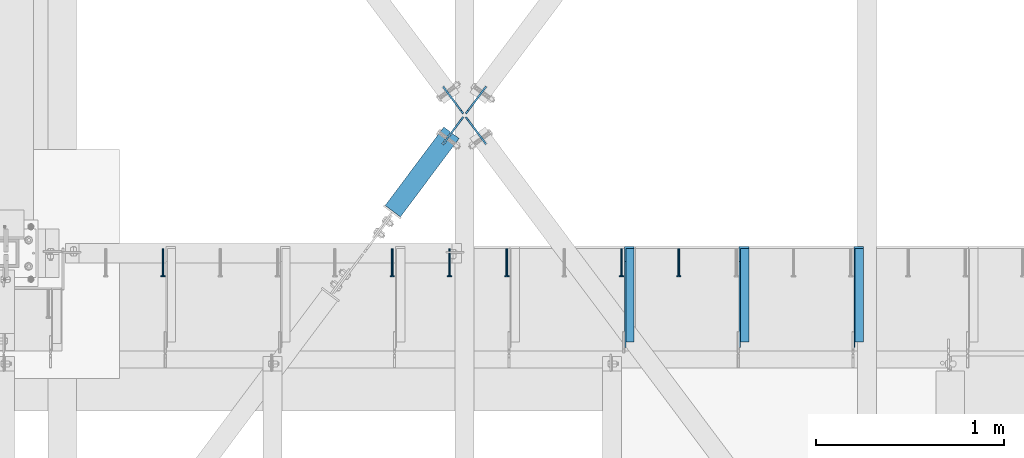
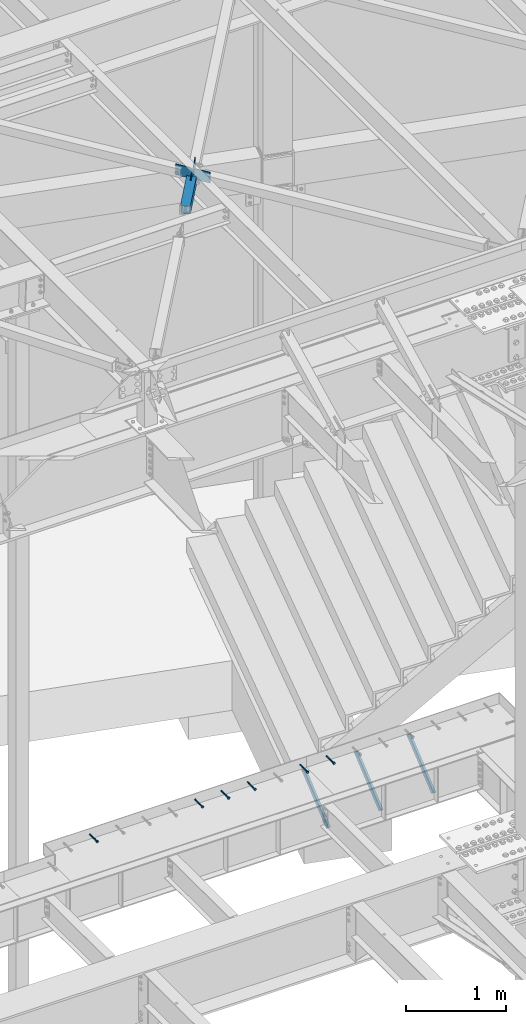
# One storey, part 1362 of 1763: 11 beams, 3 members, 9 elements without a shape of their own.
"""IFC2X3 building model written with IfcOpenShell, lengths in millimetres."""

from ifc_helpers import new_model, si_unit, frame, origin_with_axes, place, context, subcontext, project, spatial, faceted_brep, material, type_object, element, aggregate, save


model = new_model("IFC2X3")

# Units and contexts
model_context = context("Model", 3, precision=1e-05, world=origin_with_axes())
body_context = subcontext(model_context, "Body", "Model", "MODEL_VIEW")
ifc_project = project(units=[si_unit("LENGTHUNIT", "METRE", prefix="MILLI"), si_unit("AREAUNIT", "SQUARE_METRE"), si_unit("VOLUMEUNIT", "CUBIC_METRE"), si_unit("MASSUNIT", "GRAM", prefix="KILO"), si_unit("TIMEUNIT", "SECOND"), si_unit("PLANEANGLEUNIT", "RADIAN"), si_unit("SOLIDANGLEUNIT", "STERADIAN"), si_unit("THERMODYNAMICTEMPERATUREUNIT", "DEGREE_CELSIUS"), si_unit("LUMINOUSINTENSITYUNIT", "LUMEN")], contexts=[model_context])

# Site, building, storey
site_placement = place(None, origin_with_axes())
site = spatial("IfcSite", under=ifc_project, at=site_placement, CompositionType="ELEMENT")
building_placement = place(site_placement, origin_with_axes())
building = spatial("IfcBuilding", under=site, at=building_placement, Name="Undefined", CompositionType="ELEMENT")
storey_placement = place(building_placement, origin_with_axes())
storey = spatial("IfcBuildingStorey", under=building, at=storey_placement, Name="Undefined", CompositionType="ELEMENT", Elevation=0.0)

# Assembly, beam
assembly_1_placement = place(storey_placement, origin_with_axes())
assembly_1 = element("IfcElementAssembly", 1, at=assembly_1_placement, inside=storey, Name="HEADED STUD ANCHOR", AssemblyPlace="NOTDEFINED", PredefinedType="RIGID_FRAME")
ifc_material_1 = material(Name="STEEL/A108")
beam_type_1 = type_object("IfcBeamType", PredefinedType="NOTDEFINED")
beam_1_placement = place(assembly_1_placement, frame((-36392.8747736983, 54203.6, 5264.23140606069), z_axis=(0.0, 0.0, 1.0), x_axis=(0.0, -1.0, 0.0)))
beam_1 = element("IfcBeam", 2, at=beam_1_placement, type_object=beam_type_1, material=ifc_material_1, Name="HEADED STUD ANCHOR", context=body_context, shape_type="Brep", body=[
    faceted_brep([(0.0, -3.1800000667572, 5.5), (0.0, -5.5, 3.1800000667572), (141.732000000002, -5.5, 3.1800000667572), (141.732000000002, -3.1800000667572, 5.5), (0.0, -6.34999999999491, 1.45519152283669e-11), (141.732000000002, -6.34999990463257, 0.0), (0.0, -5.5, -3.1800000667572), (141.732000000002, -5.5, -3.1800000667572), (0.0, -3.1800000667572, -5.5), (141.732000000002, -3.1800000667572, -5.5), (0.0, 0.0, -6.34999990463257), (141.732000000002, 0.0, -6.34999990463257), (0.0, 3.1800000667572, -5.5), (141.732000000002, 3.1800000667572, -5.5), (0.0, 5.5, -3.1800000667572), (141.732000000002, 5.5, -3.1800000667572), (0.0, 6.34999999999491, -2.91038304567337e-11), (141.732000000002, 6.34999990463257, 0.0), (0.0, 5.5, 3.1800000667572), (141.732000000002, 5.5, 3.1800000667572), (0.0, 3.1800000667572, 5.5), (141.732000000002, 3.1800000667572, 5.5), (0.0, 0.0, 6.34999990463257), (141.732000000002, 0.0, 6.34999990463257), (144.780000000001, -10.9899997711182, 6.34999990463257), (144.780000000001, -6.34000015258789, 10.9899997711182), (144.780000000001, -12.6999998092651, 0.0), (144.780000000001, -10.9899997711182, -6.34999990463257), (144.780000000001, -6.34000015258789, -10.9899997711182), (144.780000000001, 0.0, -12.6899995803833), (144.780000000001, 6.34000015258789, -10.9899997711182), (144.780000000001, 10.9899997711182, -6.34999990463257), (144.780000000001, 12.6999998092651, 0.0), (144.780000000001, 10.9899997711182, 6.34999990463257), (144.780000000001, 6.34000015258789, 10.9899997711182), (144.780000000001, 0.0, 12.6899995803833), (152.400000000001, -10.9899997711182, 6.34999990463257), (152.400000000001, -6.34000015258789, 10.9899997711182), (152.400000000001, -12.6999998092651, 0.0), (152.400000000001, -10.9899997711182, -6.34999990463257), (152.400000000001, -6.34000015258789, -10.9899997711182), (152.400000000001, 0.0, -12.6899995803833), (152.400000000001, 6.34000015258789, -10.9899997711182), (152.400000000001, 10.9899997711182, -6.34999990463257), (152.400000000001, 12.6999998092651, 0.0), (152.400000000001, 10.9899997711182, 6.34999990463257), (152.400000000001, 6.34000015258789, 10.9899997711182), (152.400000000001, 0.0, 12.6899995803833)], [[[0, 1, 2, 3]], [[1, 4, 5, 2]], [[4, 6, 7, 5]], [[6, 8, 9, 7]], [[8, 10, 11, 9]], [[10, 12, 13, 11]], [[12, 14, 15, 13]], [[14, 16, 17, 15]], [[16, 18, 19, 17]], [[18, 20, 21, 19]], [[20, 22, 23, 21]], [[22, 0, 3, 23]], [[22, 20, 18, 16, 14, 12, 10, 8, 6, 4, 1, 0]], [[3, 2, 24, 25]], [[2, 5, 26, 24]], [[5, 7, 27, 26]], [[7, 9, 28, 27]], [[9, 11, 29, 28]], [[11, 13, 30, 29]], [[13, 15, 31, 30]], [[15, 17, 32, 31]], [[17, 19, 33, 32]], [[19, 21, 34, 33]], [[21, 23, 35, 34]], [[23, 3, 25, 35]], [[25, 24, 36, 37]], [[24, 26, 38, 36]], [[26, 27, 39, 38]], [[27, 28, 40, 39]], [[28, 29, 41, 40]], [[29, 30, 42, 41]], [[30, 31, 43, 42]], [[31, 32, 44, 43]], [[32, 33, 45, 44]], [[33, 34, 46, 45]], [[34, 35, 47, 46]], [[35, 25, 37, 47]], [[38, 39, 40, 41, 42, 43, 44, 45, 46, 47, 37, 36]]]),
])
aggregate(assembly_1, [beam_1])

assembly_2_placement = place(storey_placement, origin_with_axes())
assembly_2 = element("IfcElementAssembly", 3, at=assembly_2_placement, inside=storey, Name="HEADED STUD ANCHOR", AssemblyPlace="NOTDEFINED", PredefinedType="RIGID_FRAME")
beam_2_placement = place(assembly_2_placement, frame((-36697.6747736983, 54203.6, 5264.23140606069), z_axis=(0.0, 0.0, 1.0), x_axis=(0.0, -1.0, 0.0)))
beam_2 = element("IfcBeam", 4, at=beam_2_placement, type_object=beam_type_1, material=ifc_material_1, Name="HEADED STUD ANCHOR", context=body_context, shape_type="Brep", body=[
    faceted_brep([(0.0, -3.1800000667572, 5.5), (0.0, -5.5, 3.1800000667572), (141.732000000002, -5.5, 3.1800000667572), (141.732000000002, -3.1800000667572, 5.5), (0.0, -6.34999999999491, 1.45519152283669e-11), (141.732000000002, -6.34999990463257, 0.0), (0.0, -5.5, -3.1800000667572), (141.732000000002, -5.5, -3.1800000667572), (0.0, -3.1800000667572, -5.5), (141.732000000002, -3.1800000667572, -5.5), (0.0, 0.0, -6.34999990463257), (141.732000000002, 0.0, -6.34999990463257), (0.0, 3.1800000667572, -5.5), (141.732000000002, 3.1800000667572, -5.5), (0.0, 5.5, -3.1800000667572), (141.732000000002, 5.5, -3.1800000667572), (0.0, 6.34999999999491, -2.91038304567337e-11), (141.732000000002, 6.34999990463257, 0.0), (0.0, 5.5, 3.1800000667572), (141.732000000002, 5.5, 3.1800000667572), (0.0, 3.1800000667572, 5.5), (141.732000000002, 3.1800000667572, 5.5), (0.0, 0.0, 6.34999990463257), (141.732000000002, 0.0, 6.34999990463257), (144.780000000001, -10.9899997711182, 6.34999990463257), (144.780000000001, -6.34000015258789, 10.9899997711182), (144.780000000001, -12.6999998092651, 0.0), (144.780000000001, -10.9899997711182, -6.34999990463257), (144.780000000001, -6.34000015258789, -10.9899997711182), (144.780000000001, 0.0, -12.6899995803833), (144.780000000001, 6.34000015258789, -10.9899997711182), (144.780000000001, 10.9899997711182, -6.34999990463257), (144.780000000001, 12.6999998092651, 0.0), (144.780000000001, 10.9899997711182, 6.34999990463257), (144.780000000001, 6.34000015258789, 10.9899997711182), (144.780000000001, 0.0, 12.6899995803833), (152.400000000001, -10.9899997711182, 6.34999990463257), (152.400000000001, -6.34000015258789, 10.9899997711182), (152.400000000001, -12.6999998092651, 0.0), (152.400000000001, -10.9899997711182, -6.34999990463257), (152.400000000001, -6.34000015258789, -10.9899997711182), (152.400000000001, 0.0, -12.6899995803833), (152.400000000001, 6.34000015258789, -10.9899997711182), (152.400000000001, 10.9899997711182, -6.34999990463257), (152.400000000001, 12.6999998092651, 0.0), (152.400000000001, 10.9899997711182, 6.34999990463257), (152.400000000001, 6.34000015258789, 10.9899997711182), (152.400000000001, 0.0, 12.6899995803833)], [[[0, 1, 2, 3]], [[1, 4, 5, 2]], [[4, 6, 7, 5]], [[6, 8, 9, 7]], [[8, 10, 11, 9]], [[10, 12, 13, 11]], [[12, 14, 15, 13]], [[14, 16, 17, 15]], [[16, 18, 19, 17]], [[18, 20, 21, 19]], [[20, 22, 23, 21]], [[22, 0, 3, 23]], [[22, 20, 18, 16, 14, 12, 10, 8, 6, 4, 1, 0]], [[3, 2, 24, 25]], [[2, 5, 26, 24]], [[5, 7, 27, 26]], [[7, 9, 28, 27]], [[9, 11, 29, 28]], [[11, 13, 30, 29]], [[13, 15, 31, 30]], [[15, 17, 32, 31]], [[17, 19, 33, 32]], [[19, 21, 34, 33]], [[21, 23, 35, 34]], [[23, 3, 25, 35]], [[25, 24, 36, 37]], [[24, 26, 38, 36]], [[26, 27, 39, 38]], [[27, 28, 40, 39]], [[28, 29, 41, 40]], [[29, 30, 42, 41]], [[30, 31, 43, 42]], [[31, 32, 44, 43]], [[32, 33, 45, 44]], [[33, 34, 46, 45]], [[34, 35, 47, 46]], [[35, 25, 37, 47]], [[38, 39, 40, 41, 42, 43, 44, 45, 46, 47, 37, 36]]]),
])
aggregate(assembly_2, [beam_2])

assembly_3_placement = place(storey_placement, origin_with_axes())
assembly_3 = element("IfcElementAssembly", 5, at=assembly_3_placement, inside=storey, Name="HEADED STUD ANCHOR", AssemblyPlace="NOTDEFINED", PredefinedType="RIGID_FRAME")
beam_3_placement = place(assembly_3_placement, frame((-37307.2747736983, 54203.6, 5264.23140606069), z_axis=(0.0, 0.0, 1.0), x_axis=(0.0, -1.0, 0.0)))
beam_3 = element("IfcBeam", 6, at=beam_3_placement, type_object=beam_type_1, material=ifc_material_1, Name="HEADED STUD ANCHOR", context=body_context, shape_type="Brep", body=[
    faceted_brep([(0.0, -3.1800000667572, 5.5), (0.0, -5.5, 3.1800000667572), (141.732000000002, -5.5, 3.1800000667572), (141.732000000002, -3.1800000667572, 5.5), (0.0, -6.34999999999491, 1.45519152283669e-11), (141.732000000002, -6.34999990463257, 0.0), (0.0, -5.5, -3.1800000667572), (141.732000000002, -5.5, -3.1800000667572), (0.0, -3.1800000667572, -5.5), (141.732000000002, -3.1800000667572, -5.5), (0.0, 0.0, -6.34999990463257), (141.732000000002, 0.0, -6.34999990463257), (0.0, 3.1800000667572, -5.5), (141.732000000002, 3.1800000667572, -5.5), (0.0, 5.5, -3.1800000667572), (141.732000000002, 5.5, -3.1800000667572), (0.0, 6.34999999999491, -2.91038304567337e-11), (141.732000000002, 6.34999990463257, 0.0), (0.0, 5.5, 3.1800000667572), (141.732000000002, 5.5, 3.1800000667572), (0.0, 3.1800000667572, 5.5), (141.732000000002, 3.1800000667572, 5.5), (0.0, 0.0, 6.34999990463257), (141.732000000002, 0.0, 6.34999990463257), (144.780000000001, -10.9899997711182, 6.34999990463257), (144.780000000001, -6.34000015258789, 10.9899997711182), (144.780000000001, -12.6999998092651, 0.0), (144.780000000001, -10.9899997711182, -6.34999990463257), (144.780000000001, -6.34000015258789, -10.9899997711182), (144.780000000001, 0.0, -12.6899995803833), (144.780000000001, 6.34000015258789, -10.9899997711182), (144.780000000001, 10.9899997711182, -6.34999990463257), (144.780000000001, 12.6999998092651, 0.0), (144.780000000001, 10.9899997711182, 6.34999990463257), (144.780000000001, 6.34000015258789, 10.9899997711182), (144.780000000001, 0.0, 12.6899995803833), (152.400000000001, -10.9899997711182, 6.34999990463257), (152.400000000001, -6.34000015258789, 10.9899997711182), (152.400000000001, -12.6999998092651, 0.0), (152.400000000001, -10.9899997711182, -6.34999990463257), (152.400000000001, -6.34000015258789, -10.9899997711182), (152.400000000001, 0.0, -12.6899995803833), (152.400000000001, 6.34000015258789, -10.9899997711182), (152.400000000001, 10.9899997711182, -6.34999990463257), (152.400000000001, 12.6999998092651, 0.0), (152.400000000001, 10.9899997711182, 6.34999990463257), (152.400000000001, 6.34000015258789, 10.9899997711182), (152.400000000001, 0.0, 12.6899995803833)], [[[0, 1, 2, 3]], [[1, 4, 5, 2]], [[4, 6, 7, 5]], [[6, 8, 9, 7]], [[8, 10, 11, 9]], [[10, 12, 13, 11]], [[12, 14, 15, 13]], [[14, 16, 17, 15]], [[16, 18, 19, 17]], [[18, 20, 21, 19]], [[20, 22, 23, 21]], [[22, 0, 3, 23]], [[22, 20, 18, 16, 14, 12, 10, 8, 6, 4, 1, 0]], [[3, 2, 24, 25]], [[2, 5, 26, 24]], [[5, 7, 27, 26]], [[7, 9, 28, 27]], [[9, 11, 29, 28]], [[11, 13, 30, 29]], [[13, 15, 31, 30]], [[15, 17, 32, 31]], [[17, 19, 33, 32]], [[19, 21, 34, 33]], [[21, 23, 35, 34]], [[23, 3, 25, 35]], [[25, 24, 36, 37]], [[24, 26, 38, 36]], [[26, 27, 39, 38]], [[27, 28, 40, 39]], [[28, 29, 41, 40]], [[29, 30, 42, 41]], [[30, 31, 43, 42]], [[31, 32, 44, 43]], [[32, 33, 45, 44]], [[33, 34, 46, 45]], [[34, 35, 47, 46]], [[35, 25, 37, 47]], [[38, 39, 40, 41, 42, 43, 44, 45, 46, 47, 37, 36]]]),
])
aggregate(assembly_3, [beam_3])

assembly_4_placement = place(storey_placement, origin_with_axes())
assembly_4 = element("IfcElementAssembly", 7, at=assembly_4_placement, inside=storey, Name="HEADED STUD ANCHOR", AssemblyPlace="NOTDEFINED", PredefinedType="RIGID_FRAME")
beam_4_placement = place(assembly_4_placement, frame((-37612.0747736983, 54203.6, 5264.23140606069), z_axis=(0.0, 0.0, 1.0), x_axis=(0.0, -1.0, 0.0)))
beam_4 = element("IfcBeam", 8, at=beam_4_placement, type_object=beam_type_1, material=ifc_material_1, Name="HEADED STUD ANCHOR", context=body_context, shape_type="Brep", body=[
    faceted_brep([(0.0, -3.1800000667572, 5.5), (0.0, -5.5, 3.1800000667572), (141.732000000002, -5.5, 3.1800000667572), (141.732000000002, -3.1800000667572, 5.5), (0.0, -6.34999999999491, 1.45519152283669e-11), (141.732000000002, -6.34999990463257, 0.0), (0.0, -5.5, -3.1800000667572), (141.732000000002, -5.5, -3.1800000667572), (0.0, -3.1800000667572, -5.5), (141.732000000002, -3.1800000667572, -5.5), (0.0, 0.0, -6.34999990463257), (141.732000000002, 0.0, -6.34999990463257), (0.0, 3.1800000667572, -5.5), (141.732000000002, 3.1800000667572, -5.5), (0.0, 5.5, -3.1800000667572), (141.732000000002, 5.5, -3.1800000667572), (0.0, 6.34999999999491, -2.91038304567337e-11), (141.732000000002, 6.34999990463257, 0.0), (0.0, 5.5, 3.1800000667572), (141.732000000002, 5.5, 3.1800000667572), (0.0, 3.1800000667572, 5.5), (141.732000000002, 3.1800000667572, 5.5), (0.0, 0.0, 6.34999990463257), (141.732000000002, 0.0, 6.34999990463257), (144.780000000001, -10.9899997711182, 6.34999990463257), (144.780000000001, -6.34000015258789, 10.9899997711182), (144.780000000001, -12.6999998092651, 0.0), (144.780000000001, -10.9899997711182, -6.34999990463257), (144.780000000001, -6.34000015258789, -10.9899997711182), (144.780000000001, 0.0, -12.6899995803833), (144.780000000001, 6.34000015258789, -10.9899997711182), (144.780000000001, 10.9899997711182, -6.34999990463257), (144.780000000001, 12.6999998092651, 0.0), (144.780000000001, 10.9899997711182, 6.34999990463257), (144.780000000001, 6.34000015258789, 10.9899997711182), (144.780000000001, 0.0, 12.6899995803833), (152.400000000001, -10.9899997711182, 6.34999990463257), (152.400000000001, -6.34000015258789, 10.9899997711182), (152.400000000001, -12.6999998092651, 0.0), (152.400000000001, -10.9899997711182, -6.34999990463257), (152.400000000001, -6.34000015258789, -10.9899997711182), (152.400000000001, 0.0, -12.6899995803833), (152.400000000001, 6.34000015258789, -10.9899997711182), (152.400000000001, 10.9899997711182, -6.34999990463257), (152.400000000001, 12.6999998092651, 0.0), (152.400000000001, 10.9899997711182, 6.34999990463257), (152.400000000001, 6.34000015258789, 10.9899997711182), (152.400000000001, 0.0, 12.6899995803833)], [[[0, 1, 2, 3]], [[1, 4, 5, 2]], [[4, 6, 7, 5]], [[6, 8, 9, 7]], [[8, 10, 11, 9]], [[10, 12, 13, 11]], [[12, 14, 15, 13]], [[14, 16, 17, 15]], [[16, 18, 19, 17]], [[18, 20, 21, 19]], [[20, 22, 23, 21]], [[22, 0, 3, 23]], [[22, 20, 18, 16, 14, 12, 10, 8, 6, 4, 1, 0]], [[3, 2, 24, 25]], [[2, 5, 26, 24]], [[5, 7, 27, 26]], [[7, 9, 28, 27]], [[9, 11, 29, 28]], [[11, 13, 30, 29]], [[13, 15, 31, 30]], [[15, 17, 32, 31]], [[17, 19, 33, 32]], [[19, 21, 34, 33]], [[21, 23, 35, 34]], [[23, 3, 25, 35]], [[25, 24, 36, 37]], [[24, 26, 38, 36]], [[26, 27, 39, 38]], [[27, 28, 40, 39]], [[28, 29, 41, 40]], [[29, 30, 42, 41]], [[30, 31, 43, 42]], [[31, 32, 44, 43]], [[32, 33, 45, 44]], [[33, 34, 46, 45]], [[34, 35, 47, 46]], [[35, 25, 37, 47]], [[38, 39, 40, 41, 42, 43, 44, 45, 46, 47, 37, 36]]]),
])
aggregate(assembly_4, [beam_4])

assembly_5_placement = place(storey_placement, origin_with_axes())
assembly_5 = element("IfcElementAssembly", 9, at=assembly_5_placement, inside=storey, Name="HEADED STUD ANCHOR", AssemblyPlace="NOTDEFINED", PredefinedType="RIGID_FRAME")
beam_5_placement = place(assembly_5_placement, frame((-37916.8747736983, 54203.6, 5264.23140606069), z_axis=(0.0, 0.0, 1.0), x_axis=(0.0, -1.0, 0.0)))
beam_5 = element("IfcBeam", 10, at=beam_5_placement, type_object=beam_type_1, material=ifc_material_1, Name="HEADED STUD ANCHOR", context=body_context, shape_type="Brep", body=[
    faceted_brep([(0.0, -3.1800000667572, 5.5), (0.0, -5.5, 3.1800000667572), (141.732000000002, -5.5, 3.1800000667572), (141.732000000002, -3.1800000667572, 5.5), (0.0, -6.34999999999491, 1.45519152283669e-11), (141.732000000002, -6.34999990463257, 0.0), (0.0, -5.5, -3.1800000667572), (141.732000000002, -5.5, -3.1800000667572), (0.0, -3.1800000667572, -5.5), (141.732000000002, -3.1800000667572, -5.5), (0.0, 0.0, -6.34999990463257), (141.732000000002, 0.0, -6.34999990463257), (0.0, 3.1800000667572, -5.5), (141.732000000002, 3.1800000667572, -5.5), (0.0, 5.5, -3.1800000667572), (141.732000000002, 5.5, -3.1800000667572), (0.0, 6.34999999999491, -2.91038304567337e-11), (141.732000000002, 6.34999990463257, 0.0), (0.0, 5.5, 3.1800000667572), (141.732000000002, 5.5, 3.1800000667572), (0.0, 3.1800000667572, 5.5), (141.732000000002, 3.1800000667572, 5.5), (0.0, 0.0, 6.34999990463257), (141.732000000002, 0.0, 6.34999990463257), (144.780000000001, -10.9899997711182, 6.34999990463257), (144.780000000001, -6.34000015258789, 10.9899997711182), (144.780000000001, -12.6999998092651, 0.0), (144.780000000001, -10.9899997711182, -6.34999990463257), (144.780000000001, -6.34000015258789, -10.9899997711182), (144.780000000001, 0.0, -12.6899995803833), (144.780000000001, 6.34000015258789, -10.9899997711182), (144.780000000001, 10.9899997711182, -6.34999990463257), (144.780000000001, 12.6999998092651, 0.0), (144.780000000001, 10.9899997711182, 6.34999990463257), (144.780000000001, 6.34000015258789, 10.9899997711182), (144.780000000001, 0.0, 12.6899995803833), (152.400000000001, -10.9899997711182, 6.34999990463257), (152.400000000001, -6.34000015258789, 10.9899997711182), (152.400000000001, -12.6999998092651, 0.0), (152.400000000001, -10.9899997711182, -6.34999990463257), (152.400000000001, -6.34000015258789, -10.9899997711182), (152.400000000001, 0.0, -12.6899995803833), (152.400000000001, 6.34000015258789, -10.9899997711182), (152.400000000001, 10.9899997711182, -6.34999990463257), (152.400000000001, 12.6999998092651, 0.0), (152.400000000001, 10.9899997711182, 6.34999990463257), (152.400000000001, 6.34000015258789, 10.9899997711182), (152.400000000001, 0.0, 12.6899995803833)], [[[0, 1, 2, 3]], [[1, 4, 5, 2]], [[4, 6, 7, 5]], [[6, 8, 9, 7]], [[8, 10, 11, 9]], [[10, 12, 13, 11]], [[12, 14, 15, 13]], [[14, 16, 17, 15]], [[16, 18, 19, 17]], [[18, 20, 21, 19]], [[20, 22, 23, 21]], [[22, 0, 3, 23]], [[22, 20, 18, 16, 14, 12, 10, 8, 6, 4, 1, 0]], [[3, 2, 24, 25]], [[2, 5, 26, 24]], [[5, 7, 27, 26]], [[7, 9, 28, 27]], [[9, 11, 29, 28]], [[11, 13, 30, 29]], [[13, 15, 31, 30]], [[15, 17, 32, 31]], [[17, 19, 33, 32]], [[19, 21, 34, 33]], [[21, 23, 35, 34]], [[23, 3, 25, 35]], [[25, 24, 36, 37]], [[24, 26, 38, 36]], [[26, 27, 39, 38]], [[27, 28, 40, 39]], [[28, 29, 41, 40]], [[29, 30, 42, 41]], [[30, 31, 43, 42]], [[31, 32, 44, 43]], [[32, 33, 45, 44]], [[33, 34, 46, 45]], [[34, 35, 47, 46]], [[35, 25, 37, 47]], [[38, 39, 40, 41, 42, 43, 44, 45, 46, 47, 37, 36]]]),
])
aggregate(assembly_5, [beam_5])

assembly_6_placement = place(storey_placement, origin_with_axes())
assembly_6 = element("IfcElementAssembly", 11, at=assembly_6_placement, inside=storey, Name="HEADED STUD ANCHOR", AssemblyPlace="NOTDEFINED", PredefinedType="RIGID_FRAME")
beam_6_placement = place(assembly_6_placement, frame((-39136.0747736983, 54203.6, 5264.23140606069), z_axis=(0.0, 0.0, 1.0), x_axis=(0.0, -1.0, 0.0)))
beam_6 = element("IfcBeam", 12, at=beam_6_placement, type_object=beam_type_1, material=ifc_material_1, Name="HEADED STUD ANCHOR", context=body_context, shape_type="Brep", body=[
    faceted_brep([(0.0, -3.1800000667572, 5.5), (0.0, -5.5, 3.1800000667572), (141.732000000002, -5.5, 3.1800000667572), (141.732000000002, -3.1800000667572, 5.5), (0.0, -6.34999999999491, 1.45519152283669e-11), (141.732000000002, -6.34999990463257, 0.0), (0.0, -5.5, -3.1800000667572), (141.732000000002, -5.5, -3.1800000667572), (0.0, -3.1800000667572, -5.5), (141.732000000002, -3.1800000667572, -5.5), (0.0, 0.0, -6.34999990463257), (141.732000000002, 0.0, -6.34999990463257), (0.0, 3.1800000667572, -5.5), (141.732000000002, 3.1800000667572, -5.5), (0.0, 5.5, -3.1800000667572), (141.732000000002, 5.5, -3.1800000667572), (0.0, 6.34999999999491, -2.91038304567337e-11), (141.732000000002, 6.34999990463257, 0.0), (0.0, 5.5, 3.1800000667572), (141.732000000002, 5.5, 3.1800000667572), (0.0, 3.1800000667572, 5.5), (141.732000000002, 3.1800000667572, 5.5), (0.0, 0.0, 6.34999990463257), (141.732000000002, 0.0, 6.34999990463257), (144.780000000001, -10.9899997711182, 6.34999990463257), (144.780000000001, -6.34000015258789, 10.9899997711182), (144.780000000001, -12.6999998092651, 0.0), (144.780000000001, -10.9899997711182, -6.34999990463257), (144.780000000001, -6.34000015258789, -10.9899997711182), (144.780000000001, 0.0, -12.6899995803833), (144.780000000001, 6.34000015258789, -10.9899997711182), (144.780000000001, 10.9899997711182, -6.34999990463257), (144.780000000001, 12.6999998092651, 0.0), (144.780000000001, 10.9899997711182, 6.34999990463257), (144.780000000001, 6.34000015258789, 10.9899997711182), (144.780000000001, 0.0, 12.6899995803833), (152.400000000001, -10.9899997711182, 6.34999990463257), (152.400000000001, -6.34000015258789, 10.9899997711182), (152.400000000001, -12.6999998092651, 0.0), (152.400000000001, -10.9899997711182, -6.34999990463257), (152.400000000001, -6.34000015258789, -10.9899997711182), (152.400000000001, 0.0, -12.6899995803833), (152.400000000001, 6.34000015258789, -10.9899997711182), (152.400000000001, 10.9899997711182, -6.34999990463257), (152.400000000001, 12.6999998092651, 0.0), (152.400000000001, 10.9899997711182, 6.34999990463257), (152.400000000001, 6.34000015258789, 10.9899997711182), (152.400000000001, 0.0, 12.6899995803833)], [[[0, 1, 2, 3]], [[1, 4, 5, 2]], [[4, 6, 7, 5]], [[6, 8, 9, 7]], [[8, 10, 11, 9]], [[10, 12, 13, 11]], [[12, 14, 15, 13]], [[14, 16, 17, 15]], [[16, 18, 19, 17]], [[18, 20, 21, 19]], [[20, 22, 23, 21]], [[22, 0, 3, 23]], [[22, 20, 18, 16, 14, 12, 10, 8, 6, 4, 1, 0]], [[3, 2, 24, 25]], [[2, 5, 26, 24]], [[5, 7, 27, 26]], [[7, 9, 28, 27]], [[9, 11, 29, 28]], [[11, 13, 30, 29]], [[13, 15, 31, 30]], [[15, 17, 32, 31]], [[17, 19, 33, 32]], [[19, 21, 34, 33]], [[21, 23, 35, 34]], [[23, 3, 25, 35]], [[25, 24, 36, 37]], [[24, 26, 38, 36]], [[26, 27, 39, 38]], [[27, 28, 40, 39]], [[28, 29, 41, 40]], [[29, 30, 42, 41]], [[30, 31, 43, 42]], [[31, 32, 44, 43]], [[32, 33, 45, 44]], [[33, 34, 46, 45]], [[34, 35, 47, 46]], [[35, 25, 37, 47]], [[38, 39, 40, 41, 42, 43, 44, 45, 46, 47, 37, 36]]]),
])
aggregate(assembly_6, [beam_6])

# Assembly, members
assembly_7_placement = place(storey_placement, origin_with_axes())
assembly_7 = element("IfcElementAssembly", 13, at=assembly_7_placement, inside=storey, Name="BEAM", AssemblyPlace="NOTDEFINED", PredefinedType="RIGID_FRAME")
ifc_material_2 = material(Name="STEEL/A36")
member_type = type_object("IfcMemberType", Name="L2X2X1/4", PredefinedType="NOTDEFINED")
member_1_placement = place(assembly_7_placement, frame((-35436.6044734054, 53692.8752601513, 4792.34833807684), z_axis=(0.0, -0.641507205139845, 0.767117009167223), x_axis=(0.0, 0.767117009167224, 0.641507205139844)))
member_1 = element("IfcMember", 14, at=member_1_placement, type_object=member_type, material=ifc_material_2, Name="ANGLE", ObjectType="L2X2X1/4", context=body_context, shape_type="Brep", body=[
    faceted_brep([(-1.45519152283669e-11, 25.4000000000015, -25.3999999999869), (1.45519152283669e-11, 25.4000000000015, 25.3999999999796), (596.200457969971, 25.4000000000015, 25.3999999984771), (656.947310752032, 25.4000000000015, -25.4000000016313), (1.45519152283669e-11, 19.0499999999993, 25.3999999999796), (596.200457969971, 19.0500000000029, 25.3999999984771), (-7.27595761418343e-12, 19.0499999999993, -19.0499999999956), (649.35395415427, 19.0500000000029, -19.0500000016218), (-7.27595761418343e-12, -25.4000000000015, -19.0499999999956), (649.35395415427, -25.4000000000015, -19.0500000016218), (-1.45519152283669e-11, -25.4000000000015, -25.3999999999869), (656.947310752032, -25.4000000000015, -25.4000000016313)], [[[0, 1, 2, 3]], [[1, 4, 5, 2]], [[4, 6, 7, 5]], [[6, 8, 9, 7]], [[8, 10, 11, 9]], [[10, 0, 3, 11]], [[5, 7, 9, 11, 3, 2]], [[10, 8, 6, 4, 1, 0]]]),
])
member_2_placement = place(assembly_7_placement, frame((-36046.2044734054, 53692.8752601513, 4792.34833807684), z_axis=(0.0, -0.641507205139845, 0.767117009167223), x_axis=(0.0, 0.767117009167224, 0.641507205139844)))
member_2 = element("IfcMember", 15, at=member_2_placement, type_object=member_type, material=ifc_material_2, Name="ANGLE", ObjectType="L2X2X1/4", context=body_context, shape_type="Brep", body=[
    faceted_brep([(-1.45519152283669e-11, 25.4000000000015, -25.3999999999869), (1.45519152283669e-11, 25.4000000000015, 25.3999999999796), (596.200457969971, 25.4000000000015, 25.3999999984771), (656.947310752032, 25.4000000000015, -25.4000000016313), (1.45519152283669e-11, 19.0499999999993, 25.3999999999796), (596.200457969971, 19.0500000000029, 25.3999999984771), (-7.27595761418343e-12, 19.0499999999993, -19.0499999999956), (649.35395415427, 19.0500000000029, -19.0500000016218), (-7.27595761418343e-12, -25.4000000000015, -19.0499999999956), (649.35395415427, -25.4000000000015, -19.0500000016218), (-1.45519152283669e-11, -25.4000000000015, -25.3999999999869), (656.947310752032, -25.4000000000015, -25.4000000016313)], [[[0, 1, 2, 3]], [[1, 4, 5, 2]], [[4, 6, 7, 5]], [[6, 8, 9, 7]], [[8, 10, 11, 9]], [[10, 0, 3, 11]], [[5, 7, 9, 11, 3, 2]], [[10, 8, 6, 4, 1, 0]]]),
])
member_3_placement = place(assembly_7_placement, frame((-36655.8044734054, 53692.8752601513, 4792.34833807684), z_axis=(0.0, -0.641507205139845, 0.767117009167223), x_axis=(0.0, 0.767117009167224, 0.641507205139844)))
member_3 = element("IfcMember", 16, at=member_3_placement, type_object=member_type, material=ifc_material_2, Name="ANGLE", ObjectType="L2X2X1/4", context=body_context, shape_type="Brep", body=[
    faceted_brep([(-1.45519152283669e-11, 25.4000000000015, -25.3999999999869), (1.45519152283669e-11, 25.4000000000015, 25.3999999999796), (596.200457969971, 25.4000000000015, 25.3999999984771), (656.947310752032, 25.4000000000015, -25.4000000016313), (1.45519152283669e-11, 19.0499999999993, 25.3999999999796), (596.200457969971, 19.0500000000029, 25.3999999984771), (-7.27595761418343e-12, 19.0499999999993, -19.0499999999956), (649.35395415427, 19.0500000000029, -19.0500000016218), (-7.27595761418343e-12, -25.4000000000015, -19.0499999999956), (649.35395415427, -25.4000000000015, -19.0500000016218), (-1.45519152283669e-11, -25.4000000000015, -25.3999999999869), (656.947310752032, -25.4000000000015, -25.4000000016313)], [[[0, 1, 2, 3]], [[1, 4, 5, 2]], [[4, 6, 7, 5]], [[6, 8, 9, 7]], [[8, 10, 11, 9]], [[10, 0, 3, 11]], [[5, 7, 9, 11, 3, 2]], [[10, 8, 6, 4, 1, 0]]]),
])
aggregate(assembly_7, [member_1, member_2, member_3])

# Assembly, beam
assembly_8_placement = place(storey_placement, origin_with_axes())
assembly_8 = element("IfcElementAssembly", 17, at=assembly_8_placement, inside=storey, Name="H. BRACE", AssemblyPlace="NOTDEFINED", PredefinedType="RIGID_FRAME")
ifc_material_3 = material()
beam_type_2 = type_object("IfcBeamType", Name="HSS4X4X3/8", PredefinedType="NOTDEFINED")
beam_7_placement = place(assembly_8_placement, frame((-37532.3396174715, 54911.6249997678, 12371.3875), z_axis=(0.0, 0.0, 1.0), x_axis=(-0.599271154042197, -0.800546116056367, 0.0)))
beam_7 = element("IfcBeam", 18, at=beam_7_placement, type_object=beam_type_2, material=ifc_material_3, Name="H. BRACE", ObjectType="HSS4X4X3/8", context=body_context, shape_type="Brep", body=[
    faceted_brep([(115.544928544972, 6.34947988857311, 50.7999999999993), (115.544928544972, 6.34947988857311, 41.2749999999996), (192.613988394674, 6.35000061375467, 41.2749999999996), (192.613988394674, 6.35000061375467, 50.7999999999993), (192.614074203546, -6.34999938604597, 50.7999999999993), (192.614074203546, -6.34999938604597, 41.2749999999996), (115.544928544969, -6.35052011179505, 41.2749999999996), (115.544928544969, -6.35052011179505, 50.7999999999993), (115.544928544972, 6.34947988857311, -41.2749999999996), (115.544928544972, 6.34947988857311, -50.7999999999993), (192.613988394674, 6.35000061375467, -50.7999999999993), (192.613988394674, 6.35000061375467, -41.2749999999996), (192.614074203546, -6.34999938604597, -41.2749999999996), (192.614074203546, -6.34999938604597, -50.7999999999993), (115.544928544969, -6.35052011179505, -50.7999999999993), (115.544928544969, -6.35052011179505, -41.2749999999996), (115.544928544976, -41.2750000003798, -41.2749999999996), (115.544928544976, -41.2750000003798, 41.2749999999996), (636.976801320783, -41.2750000015294, 41.2749999999996), (636.976801320783, -41.2750000015294, -41.2749999999996), (115.544928544969, 50.7999999998938, -50.7999999999993), (636.976801320783, 50.7999999987442, -50.7999999999993), (636.976801320783, -50.8000000015527, -50.7999999999993), (115.544928544976, -50.8000000004031, -50.7999999999993), (115.544928544976, -50.8000000004031, 50.7999999999993), (636.976801320783, -50.8000000015527, 50.7999999999993), (115.544928544965, 41.2749999998705, 41.2749999999996), (636.976801320783, 41.2749999987209, 41.2749999999996), (115.544928544965, 41.2749999998705, -41.2749999999996), (636.976801320783, 41.2749999987209, -41.2749999999996), (636.976801320783, 50.7999999987442, 50.7999999999993), (115.544928544969, 50.7999999998938, 50.7999999999993)], [[[0, 1, 2, 3]], [[4, 5, 6, 7]], [[3, 2, 5, 4]], [[8, 9, 10, 11]], [[12, 13, 14, 15]], [[11, 10, 13, 12]], [[16, 17, 18, 19]], [[9, 20, 21, 22, 23, 14, 13, 10]], [[24, 23, 22, 25]], [[17, 16, 15, 14, 23, 24, 7, 6]], [[1, 26, 27, 18, 17, 6, 5, 2]], [[26, 28, 29, 27]], [[25, 22, 21, 30], [18, 27, 29, 19]], [[20, 31, 30, 21]], [[24, 25, 30, 31, 0, 3, 4, 7]], [[31, 20, 9, 8, 28, 26, 1, 0]], [[16, 19, 29, 28, 8, 11, 12, 15]]]),
])
aggregate(assembly_8, [beam_7])

# Assembly, beams
assembly_9_placement = place(storey_placement, origin_with_axes())
assembly_9 = element("IfcElementAssembly", 19, at=assembly_9_placement, inside=storey, Name="BEAM", AssemblyPlace="NOTDEFINED", PredefinedType="RIGID_FRAME")
beam_type_3 = type_object("IfcBeamType", PredefinedType="NOTDEFINED")
beam_8_placement = place(assembly_9_placement, frame((-37593.0779399681, 54992.7632637867, 12439.6499999996), z_axis=(0.599271154042184, -0.800546116056376, 0.0), x_axis=(0.0, 0.0, -1.0)))
beam_8 = element("IfcBeam", 20, at=beam_8_placement, type_object=beam_type_3, material=ifc_material_2, Name="PLATE", context=body_context, shape_type="Brep", body=[
    faceted_brep([(19.0499992371879, -4.76250000011942, 89.6938399302744), (19.0499992371879, 4.76249999985293, 89.6934999997466), (0.0, 4.76249999988204, 70.6438406933594), (0.0, -4.76250000008667, 70.6438406933448), (0.0, -4.76249999985748, -89.6934999997466), (0.0, 4.76250000011851, -89.693499999732), (131.762500000001, 4.76250000011851, -89.693499999732), (131.762500000001, -4.76249999985748, -89.6934999997466), (131.762500000001, -4.76250000011578, 89.6934999997175), (131.762500000001, 4.76249999985293, 89.6934999997466)], [[[0, 1, 2, 3]], [[4, 5, 6, 7]], [[8, 7, 6, 9]], [[4, 7, 8, 0, 3]], [[5, 4, 3, 2]], [[9, 6, 5, 2, 1]], [[8, 9, 1, 0]]]),
])
beam_9_placement = place(assembly_9_placement, frame((-37593.0660690867, 54830.5036011911, 12439.6500000001), z_axis=(0.599265745056351, 0.800550165075279, 0.0), x_axis=(0.0, 0.0, -1.0)))
beam_9 = element("IfcBeam", 21, at=beam_9_placement, type_object=beam_type_3, material=ifc_material_2, Name="PLATE", context=body_context, shape_type="Brep", body=[
    faceted_brep([(19.0499992371879, -4.76250000011942, 89.6938399302744), (19.0499992371879, 4.76249999985293, 89.6934999997466), (0.0, 4.76249999988204, 70.6438406933594), (0.0, -4.76250000008667, 70.6438406933448), (0.0, -4.76249999985748, -89.6934999997466), (0.0, 4.76250000011851, -89.693499999732), (131.762500000001, 4.76250000011851, -89.693499999732), (131.762500000001, -4.76249999985748, -89.6934999997466), (131.762500000001, -4.76250000011578, 89.6934999997175), (131.762500000001, 4.76249999985293, 89.6934999997466)], [[[0, 1, 2, 3]], [[4, 5, 6, 7]], [[8, 7, 6, 9]], [[4, 7, 8, 0, 3]], [[5, 4, 3, 2]], [[9, 6, 5, 2, 1]], [[8, 9, 1, 0]]]),
])
beam_10_placement = place(assembly_9_placement, frame((-37471.6032233936, 54992.7564681484, 12439.65), z_axis=(-0.599248698317832, -0.800562925424594, 0.0), x_axis=(0.0, 0.0, -1.0)))
beam_10 = element("IfcBeam", 22, at=beam_10_placement, type_object=beam_type_3, material=ifc_material_2, Name="PLATE", context=body_context, shape_type="Brep", body=[
    faceted_brep([(19.0499992371879, -4.76250000011942, 89.6938399302744), (19.0499992371879, 4.76249999985293, 89.6934999997466), (0.0, 4.76249999988204, 70.6438406933594), (0.0, -4.76250000008667, 70.6438406933448), (0.0, -4.76249999985748, -89.6934999997466), (0.0, 4.76250000011851, -89.693499999732), (131.762500000001, 4.76250000011851, -89.693499999732), (131.762500000001, -4.76249999985748, -89.6934999997466), (131.762500000001, -4.76250000011578, 89.6934999997175), (131.762500000001, 4.76249999985293, 89.6934999997466)], [[[0, 1, 2, 3]], [[4, 5, 6, 7]], [[8, 7, 6, 9]], [[4, 7, 8, 0, 3]], [[5, 4, 3, 2]], [[9, 6, 5, 2, 1]], [[8, 9, 1, 0]]]),
])
beam_11_placement = place(assembly_9_placement, frame((-37471.6012949286, 54830.4867366212, 12439.6499999996), z_axis=(-0.599271154042197, 0.800546116056367, 0.0), x_axis=(0.0, 0.0, -1.0)))
beam_11 = element("IfcBeam", 23, at=beam_11_placement, type_object=beam_type_3, material=ifc_material_2, Name="PLATE", context=body_context, shape_type="Brep", body=[
    faceted_brep([(19.0499992371879, -4.76250000011942, 89.6938399302744), (19.0499992371879, 4.76249999985293, 89.6934999997466), (0.0, 4.76249999988204, 70.6438406933594), (0.0, -4.76250000008667, 70.6438406933448), (0.0, -4.76249999985748, -89.6934999997466), (0.0, 4.76250000011851, -89.693499999732), (131.762500000001, 4.76250000011851, -89.693499999732), (131.762500000001, -4.76249999985748, -89.6934999997466), (131.762500000001, -4.76250000011578, 89.6934999997175), (131.762500000001, 4.76249999985293, 89.6934999997466)], [[[0, 1, 2, 3]], [[4, 5, 6, 7]], [[8, 7, 6, 9]], [[4, 7, 8, 0, 3]], [[5, 4, 3, 2]], [[9, 6, 5, 2, 1]], [[8, 9, 1, 0]]]),
])
aggregate(assembly_9, [beam_8, beam_9, beam_10, beam_11])

save(model, "model.ifc")
